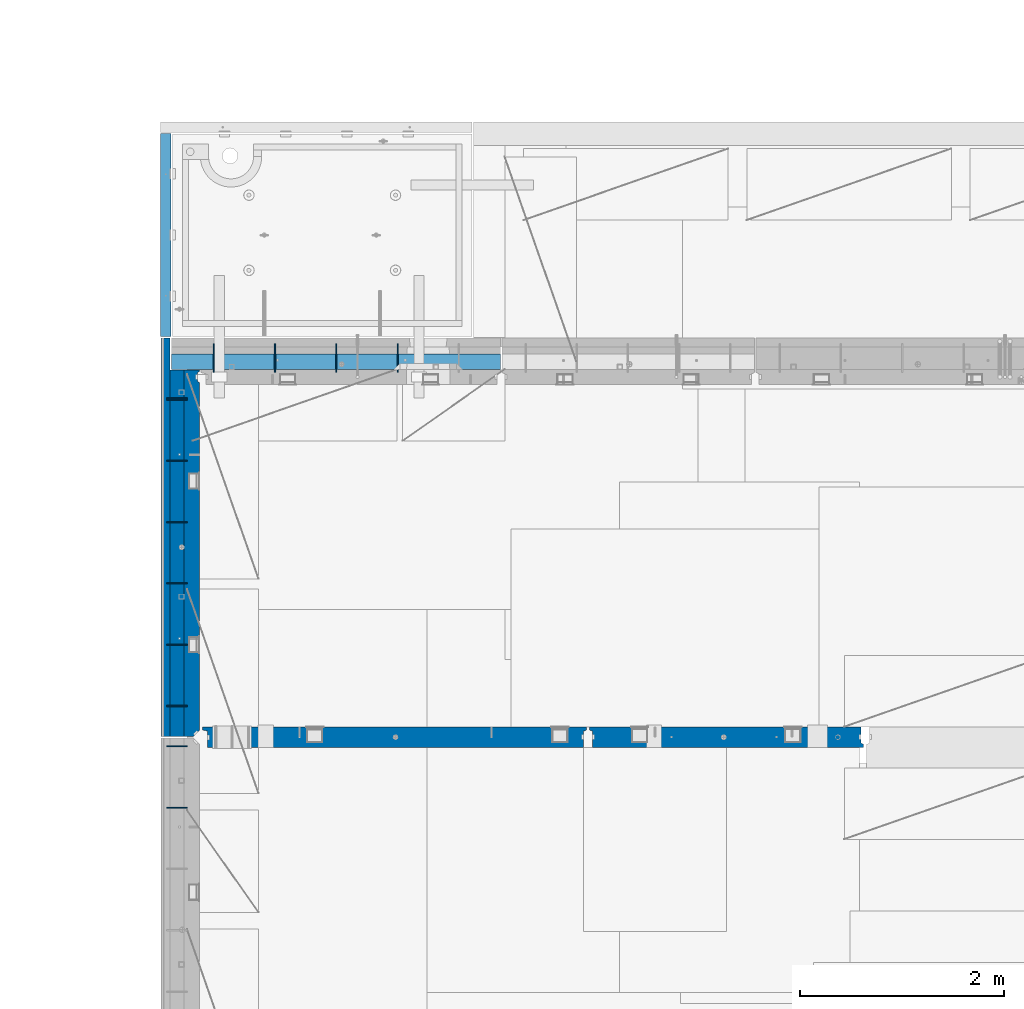
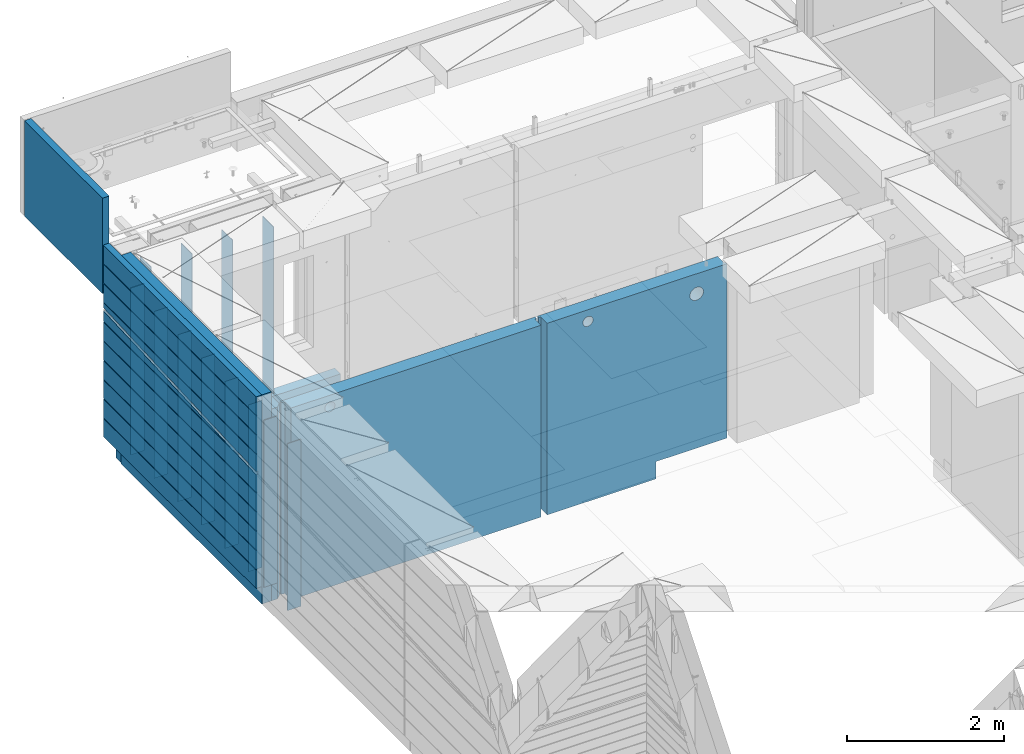
# One storey, part 214 of 325: 20 walls, 6 elements without a shape of their own.
"""IFC2X3 building model written with IfcOpenShell, lengths in millimetres."""

from ifc_helpers import new_model, si_unit, frame, origin_with_axes, place, context, subcontext, project, spatial, faceted_brep, material, type_object, element, aggregate, save


model = new_model("IFC2X3")

# Units and contexts
model_context = context("Model", 3, precision=1e-05, world=origin_with_axes())
body_context = subcontext(model_context, "Body", "Model", "MODEL_VIEW")
ifc_project = project(units=[si_unit("LENGTHUNIT", "METRE", prefix="MILLI"), si_unit("AREAUNIT", "SQUARE_METRE"), si_unit("VOLUMEUNIT", "CUBIC_METRE"), si_unit("MASSUNIT", "GRAM", prefix="KILO"), si_unit("TIMEUNIT", "SECOND"), si_unit("PLANEANGLEUNIT", "RADIAN"), si_unit("SOLIDANGLEUNIT", "STERADIAN"), si_unit("THERMODYNAMICTEMPERATUREUNIT", "DEGREE_CELSIUS"), si_unit("LUMINOUSINTENSITYUNIT", "LUMEN")], contexts=[model_context])

# Site, building, storey
site_placement = place(None, origin_with_axes())
site = spatial("IfcSite", under=ifc_project, at=site_placement, CompositionType="ELEMENT")
building_placement = place(site_placement, origin_with_axes())
building = spatial("IfcBuilding", under=site, at=building_placement, CompositionType="ELEMENT")
storey_placement = place(building_placement, origin_with_axes())
storey = spatial("IfcBuildingStorey", under=building, at=storey_placement, Name="1", CompositionType="ELEMENT", Elevation=0.0)

# Assembly, walls
assembly_1_placement = place(storey_placement, origin_with_axes())
assembly_1 = element("IfcElementAssembly", 1, at=assembly_1_placement, inside=storey, AssemblyPlace="NOTDEFINED", PredefinedType="REINFORCEMENT_UNIT")
ifc_material_1 = material(Name="Undefined")
wall_type_1 = type_object("IfcWallType", PredefinedType="NOTDEFINED")
wall_1_placement = place(assembly_1_placement, frame((7880.0, 20294.95, 83115.0), z_axis=(0.0, 0.0, 1.0), x_axis=(-1.0, 3.00000001838171e-08, 0.0)))
wall_1 = element("IfcWall", 2, at=wall_1_placement, type_object=wall_type_1, material=ifc_material_1, Name="(PD)", context=body_context, shape_type="Brep", body=[
    faceted_brep([(0.0, 5.0, -1300.0), (0.0, 5.0, 1300.0), (200.0, 5.0, 1300.0), (200.0, 5.0, -1300.0), (0.0, -5.0, 1300.0), (200.0, -5.0, 1300.0), (0.0, -5.0, -1300.0), (200.0, -5.0, -1300.0)], [[[0, 1, 2, 3]], [[1, 4, 5, 2]], [[4, 6, 7, 5]], [[6, 0, 3, 7]], [[5, 7, 3, 2]], [[6, 4, 1, 0]]]),
])
wall_2_placement = place(assembly_1_placement, frame((7880.0, 20284.95, 83115.0), z_axis=(0.0, 0.0, 1.0), x_axis=(-1.0, 3.00000001838171e-08, 0.0)))
wall_2 = element("IfcWall", 3, at=wall_2_placement, type_object=wall_type_1, material=ifc_material_1, Name="(PD)", context=body_context, shape_type="Brep", body=[
    faceted_brep([(0.0, 5.0, -1300.0), (0.0, 5.0, 1300.0), (200.0, 5.0, 1300.0), (200.0, 5.0, -1300.0), (0.0, -5.0, 1300.0), (200.0, -5.0, 1300.0), (0.0, -5.0, -1300.0), (200.0, -5.0, -1300.0)], [[[0, 1, 2, 3]], [[1, 4, 5, 2]], [[4, 6, 7, 5]], [[6, 0, 3, 7]], [[5, 7, 3, 2]], [[6, 4, 1, 0]]]),
])
wall_3_placement = place(assembly_1_placement, frame((7880.0, 19684.95, 83115.0), z_axis=(0.0, 0.0, 1.0), x_axis=(-1.0, 3.00000001838171e-08, 0.0)))
wall_3 = element("IfcWall", 4, at=wall_3_placement, type_object=wall_type_1, material=ifc_material_1, Name="(PD)", context=body_context, shape_type="Brep", body=[
    faceted_brep([(0.0, 5.0, -1300.0), (0.0, 5.0, 1300.0), (200.0, 5.0, 1300.0), (200.0, 5.0, -1300.0), (0.0, -5.0, 1300.0), (200.0, -5.0, 1300.0), (0.0, -5.0, -1300.0), (200.0, -5.0, -1300.0)], [[[0, 1, 2, 3]], [[1, 4, 5, 2]], [[4, 6, 7, 5]], [[6, 0, 3, 7]], [[5, 7, 3, 2]], [[6, 4, 1, 0]]]),
])
wall_4_placement = place(assembly_1_placement, frame((7880.0, 19084.95, 83115.0), z_axis=(0.0, 0.0, 1.0), x_axis=(-1.0, 3.00000001838171e-08, 0.0)))
wall_4 = element("IfcWall", 5, at=wall_4_placement, type_object=wall_type_1, material=ifc_material_1, Name="(PD)", context=body_context, shape_type="Brep", body=[
    faceted_brep([(0.0, 5.0, -1300.0), (0.0, 5.0, 1300.0), (200.0, 5.0, 1300.0), (200.0, 5.0, -1300.0), (0.0, -5.0, 1300.0), (200.0, -5.0, 1300.0), (0.0, -5.0, -1300.0), (200.0, -5.0, -1300.0)], [[[0, 1, 2, 3]], [[1, 4, 5, 2]], [[4, 6, 7, 5]], [[6, 0, 3, 7]], [[5, 7, 3, 2]], [[6, 4, 1, 0]]]),
])
wall_5_placement = place(assembly_1_placement, frame((7880.0, 18484.95, 83115.0), z_axis=(0.0, 0.0, 1.0), x_axis=(-1.0, 3.00000001838171e-08, 0.0)))
wall_5 = element("IfcWall", 6, at=wall_5_placement, type_object=wall_type_1, material=ifc_material_1, Name="(PD)", context=body_context, shape_type="Brep", body=[
    faceted_brep([(0.0, 5.0, -1300.0), (0.0, 5.0, 1300.0), (200.0, 5.0, 1300.0), (200.0, 5.0, -1300.0), (0.0, -5.0, 1300.0), (200.0, -5.0, 1300.0), (0.0, -5.0, -1300.0), (200.0, -5.0, -1300.0)], [[[0, 1, 2, 3]], [[1, 4, 5, 2]], [[4, 6, 7, 5]], [[6, 0, 3, 7]], [[5, 7, 3, 2]], [[6, 4, 1, 0]]]),
])
wall_6_placement = place(assembly_1_placement, frame((7880.0, 17884.95, 83115.0), z_axis=(0.0, 0.0, 1.0), x_axis=(-1.0, 3.00000001838171e-08, 0.0)))
wall_6 = element("IfcWall", 7, at=wall_6_placement, type_object=wall_type_1, material=ifc_material_1, Name="(PD)", context=body_context, shape_type="Brep", body=[
    faceted_brep([(0.0, 5.0, -1300.0), (0.0, 5.0, 1300.0), (200.0, 5.0, 1300.0), (200.0, 5.0, -1300.0), (0.0, -5.0, 1300.0), (200.0, -5.0, 1300.0), (0.0, -5.0, -1300.0), (200.0, -5.0, -1300.0)], [[[0, 1, 2, 3]], [[1, 4, 5, 2]], [[4, 6, 7, 5]], [[6, 0, 3, 7]], [[5, 7, 3, 2]], [[6, 4, 1, 0]]]),
])

assembly_2_placement = place(storey_placement, origin_with_axes())
assembly_2 = element("IfcElementAssembly", 8, at=assembly_2_placement, inside=storey, AssemblyPlace="NOTDEFINED", PredefinedType="REINFORCEMENT_UNIT")
wall_7_placement = place(assembly_2_placement, frame((7880.0, 16890.0, 83115.0), z_axis=(0.0, 0.0, 1.0), x_axis=(-1.0, 3.00000001838171e-08, 0.0)))
wall_7 = element("IfcWall", 9, at=wall_7_placement, type_object=wall_type_1, material=ifc_material_1, Name="(PD)", context=body_context, shape_type="Brep", body=[
    faceted_brep([(0.0, 5.0, -1300.0), (0.0, 5.0, 1300.0), (200.0, 5.0, 1300.0), (200.0, 5.0, -1300.0), (0.0, -5.0, 1300.0), (200.0, -5.0, 1300.0), (0.0, -5.0, -1300.0), (200.0, -5.0, -1300.0)], [[[0, 1, 2, 3]], [[1, 4, 5, 2]], [[4, 6, 7, 5]], [[6, 0, 3, 7]], [[5, 7, 3, 2]], [[6, 4, 1, 0]]]),
])
wall_8_placement = place(assembly_2_placement, frame((7880.0, 16290.0, 83115.0), z_axis=(0.0, 0.0, 1.0), x_axis=(-1.0, 3.00000001838171e-08, 0.0)))
wall_8 = element("IfcWall", 10, at=wall_8_placement, type_object=wall_type_1, material=ifc_material_1, Name="(PD)", context=body_context, shape_type="Brep", body=[
    faceted_brep([(0.0, 5.0, -1300.0), (0.0, 5.0, 1300.0), (200.0, 5.0, 1300.0), (200.0, 5.0, -1300.0), (0.0, -5.0, 1300.0), (200.0, -5.0, 1300.0), (0.0, -5.0, -1300.0), (200.0, -5.0, -1300.0)], [[[0, 1, 2, 3]], [[1, 4, 5, 2]], [[4, 6, 7, 5]], [[6, 0, 3, 7]], [[5, 7, 3, 2]], [[6, 4, 1, 0]]]),
])
aggregate(assembly_2, [wall_7, wall_8])

# Wall
wall_9_placement = place(assembly_1_placement, frame((7880.0, 17284.95, 83115.0), z_axis=(0.0, 0.0, 1.0), x_axis=(-1.0, 3.00000001838171e-08, 0.0)))
wall_9 = element("IfcWall", 11, at=wall_9_placement, type_object=wall_type_1, material=ifc_material_1, Name="(PD)", context=body_context, shape_type="Brep", body=[
    faceted_brep([(0.0, 5.0, -1300.0), (0.0, 5.0, 1300.0), (200.0, 5.0, 1300.0), (200.0, 5.0, -1300.0), (0.0, -5.0, 1300.0), (200.0, -5.0, 1300.0), (0.0, -5.0, -1300.0), (200.0, -5.0, -1300.0)], [[[0, 1, 2, 3]], [[1, 4, 5, 2]], [[4, 6, 7, 5]], [[6, 0, 3, 7]], [[5, 7, 3, 2]], [[6, 4, 1, 0]]]),
])

# Assembly, walls
assembly_3_placement = place(storey_placement, origin_with_axes())
assembly_3 = element("IfcElementAssembly", 12, at=assembly_3_placement, inside=storey, AssemblyPlace="NOTDEFINED", PredefinedType="REINFORCEMENT_UNIT")
wall_10_placement = place(assembly_3_placement, frame((8140.00024414063, 20549.9951872276, 83115.0), z_axis=(0.0, 0.0, 1.0), x_axis=(0.0, 1.0, 0.0)))
wall_10 = element("IfcWall", 13, at=wall_10_placement, type_object=wall_type_1, material=ifc_material_1, Name="(PD)", context=body_context, shape_type="Brep", body=[
    faceted_brep([(0.0, 5.0, -1300.0), (0.0, 5.0, 1300.0), (280.0, 5.0, 1300.0), (280.0, 5.0, -1300.0), (0.0, -5.0, 1300.0), (280.0, -5.0, 1300.0), (0.0, -5.0, -1300.0), (280.0, -5.0, -1300.0)], [[[0, 1, 2, 3]], [[1, 4, 5, 2]], [[4, 6, 7, 5]], [[6, 0, 3, 7]], [[5, 7, 3, 2]], [[6, 4, 1, 0]]]),
])
wall_11_placement = place(assembly_3_placement, frame((8740.00024414063, 20549.9951872276, 83115.0), z_axis=(0.0, 0.0, 1.0), x_axis=(0.0, 1.0, 0.0)))
wall_11 = element("IfcWall", 14, at=wall_11_placement, type_object=wall_type_1, material=ifc_material_1, Name="(PD)", context=body_context, shape_type="Brep", body=[
    faceted_brep([(0.0, 5.0, -1300.0), (0.0, 5.0, 1300.0), (280.0, 5.0, 1300.0), (280.0, 5.0, -1300.0), (0.0, -5.0, 1300.0), (280.0, -5.0, 1300.0), (0.0, -5.0, -1300.0), (280.0, -5.0, -1300.0)], [[[0, 1, 2, 3]], [[1, 4, 5, 2]], [[4, 6, 7, 5]], [[6, 0, 3, 7]], [[5, 7, 3, 2]], [[6, 4, 1, 0]]]),
])
wall_12_placement = place(assembly_3_placement, frame((9340.00024414063, 20549.9951872276, 83115.0), z_axis=(0.0, 0.0, 1.0), x_axis=(0.0, 1.0, 0.0)))
wall_12 = element("IfcWall", 15, at=wall_12_placement, type_object=wall_type_1, material=ifc_material_1, Name="(PD)", context=body_context, shape_type="Brep", body=[
    faceted_brep([(0.0, 5.0, -1300.0), (0.0, 5.0, 1300.0), (280.0, 5.0, 1300.0), (280.0, 5.0, -1300.0), (0.0, -5.0, 1300.0), (280.0, -5.0, 1300.0), (0.0, -5.0, -1300.0), (280.0, -5.0, -1300.0)], [[[0, 1, 2, 3]], [[1, 4, 5, 2]], [[4, 6, 7, 5]], [[6, 0, 3, 7]], [[5, 7, 3, 2]], [[6, 4, 1, 0]]]),
])
wall_13_placement = place(assembly_3_placement, frame((9940.00024414063, 20549.9951872276, 83115.0), z_axis=(0.0, 0.0, 1.0), x_axis=(0.0, 1.0, 0.0)))
wall_13 = element("IfcWall", 16, at=wall_13_placement, type_object=wall_type_1, material=ifc_material_1, Name="(PD)", context=body_context, shape_type="Brep", body=[
    faceted_brep([(0.0, 5.0, -1300.0), (0.0, 5.0, 1300.0), (280.0, 5.0, 1300.0), (280.0, 5.0, -1300.0), (0.0, -5.0, 1300.0), (280.0, -5.0, 1300.0), (0.0, -5.0, -1300.0), (280.0, -5.0, -1300.0)], [[[0, 1, 2, 3]], [[1, 4, 5, 2]], [[4, 6, 7, 5]], [[6, 0, 3, 7]], [[5, 7, 3, 2]], [[6, 4, 1, 0]]]),
])

# Wall
ifc_material_2 = material(Name="CONCRETE/C30/37")
wall_type_2 = type_object("IfcWallType", PredefinedType="NOTDEFINED")
wall_14_placement = place(assembly_1_placement, frame((7667.5, 16980.0, 83247.5), z_axis=(0.0, 0.0, 1.0), x_axis=(0.0, 1.0, 0.0)))
wall_14 = element("IfcWall", 17, at=wall_14_placement, type_object=wall_type_2, material=ifc_material_2, context=body_context, shape_type="Brep", body=[
    faceted_brep([(3905.0, 42.5, 467.601636793828), (617.757343419788, 42.5, 306.999999889245), (576.820751742882, 32.4999991121686, 305.000000400425), (372.137732831765, 32.499999250168, 294.999999999229), (331.201129576864, 42.5, 292.999999944761), (4.95000040170271, 42.5, 277.060666498321), (4.9500537408785, 12.4999999999927, 277.060666498321), (3904.99999990879, 12.4999999999927, 467.601636793828), (3905.0, 12.4999999999927, 517.601636486768), (4.95010360221204, 12.4999999999927, 327.060668622667), (4.95000040170271, 42.5, 327.060668622667), (3905.0, 42.5, 517.601636486768), (4.95000040170635, 32.499999250168, 594.999999999229), (4.95000040170635, 32.4999991121686, 605.000000400425), (3894.99999897938, 32.4999991121686, 605.000000400425), (3894.9999992586, 32.499999250168, 594.999999999229), (4.95000040170271, 32.499999250168, 894.999999999229), (4.95000040170271, 32.4999991121686, 905.000000400425), (3894.99999897938, 32.4999991121686, 905.000000400425), (3894.9999992586, 32.499999250168, 894.999999999229), (4.95000040170271, 32.499999250168, 1194.99999999923), (4.95000040170271, 32.4999991121686, 1205.00000040043), (3894.99999897938, 32.4999991121686, 1205.00000040043), (3894.9999992586, 32.499999250168, 1194.99999999923), (3905.0, 42.5, 892.999999944761), (3905.0, -42.5, 893.000001142951), (3904.99999378648, -42.5, 607.000001087436), (3905.0, 42.5, 606.999999889245), (3905.0, 42.5, 1192.99999994476), (3905.0, -42.5, 1193.00000114295), (3904.99999378648, -42.5, 907.000001087436), (3905.0, 42.5, 906.999999889245), (4.95000040170271, 42.5, 1492.5), (4.95000040170271, -42.5, 1492.5), (3905.0, -42.5, 1492.5), (3905.0, 42.5, 1492.5), (3905.0, -42.5, -1492.5), (3905.0, 42.5, -1492.5), (3905.0, 42.5, -1207.00000005524), (3905.0, -42.5, -1206.99999885705), (4.95000040170271, -42.5, -1492.5), (4.95000040170271, 42.5, -1492.5), (4.95000040170271, 42.5, -1207.00000005524), (4.95000040170271, 32.499999250168, -1205.00000000077), (3894.9999992586, 32.499999250168, -1205.00000000077), (3894.99999396347, -42.5, -1204.99999894381), (3894.99999897938, 32.4999991121686, -1194.99999959957), (3894.99999368425, -42.5, -1194.9999985426), (4.95000040170271, 32.4999991121686, -1194.99999959957), (3905.0, 42.5, -907.000000055239), (3905.0, -42.5, -906.999998857049), (3904.99999378648, -42.5, -1192.99999891256), (3905.0, 42.5, -1193.00000011075), (4.95000040170271, 32.499999250168, -905.000000000771), (4.95000040170271, 32.4999991121686, -894.999999599575), (3894.99999897938, 32.4999991121686, -894.999999599575), (3894.9999992586, 32.499999250168, -905.000000000771), (3905.0, 42.5, -607.000000055239), (3905.0, -42.5, -606.999998857049), (3904.99999378648, -42.5, -892.999998912564), (3905.0, 42.5, -893.000000110755), (4.95000040170271, 32.499999250168, -605.000000000771), (4.95000040170271, 32.4999991121686, -594.999999599575), (3894.99999897938, 32.4999991121686, -594.999999599575), (3894.9999992586, 32.499999250168, -605.000000000771), (3905.0, 42.5, -307.000000055239), (3905.0, -42.5, -306.999998857049), (3904.99999378648, -42.5, -592.999998912564), (3905.0, 42.5, -593.000000110755), (4.95000040170271, 32.499999250168, -305.000000000771), (4.95000040170271, 32.4999991121686, -294.999999599575), (3894.99999897938, 32.4999991121686, -294.999999599575), (3894.9999992586, 32.499999250168, -305.000000000771), (3905.0, 42.5, -7.00000005523907), (3905.0, -42.5, -6.99999885704892), (3904.99999378648, -42.5, -292.999998912564), (3905.0, 42.5, -293.000000110755), (3904.99999378648, -42.5, 307.000001087436), (3894.99999368425, -42.5, 305.000001457403), (3894.99999897938, 32.4999991121686, 305.000000400425), (3905.0, 42.5, 306.999999889245), (3894.99999396347, -42.5, 295.000001056193), (3894.9999992586, 32.499999250168, 294.999999999229), (3905.0, -42.5, 293.000001142951), (3905.0, 42.5, 292.999999944761), (3904.99999378648, -42.5, 7.00000108743552), (3905.0, 42.5, 6.99999988924537), (4.95000040169907, 32.499999250168, -5.00000000077125), (4.95000040169907, 32.4999991121686, 5.00000040042505), (3894.99999897938, 32.4999991121686, 5.00000040042505), (3894.9999992586, 32.499999250168, -5.00000000077125), (4.95000040170271, 42.5, 6.99999988924537), (3894.99999368425, -42.5000000000009, 5.00000145740341), (3894.99999396347, -42.5000000000009, -4.99999894380744), (4.95000040170271, 42.5, -7.00000005523907), (4.95000040170271, 42.5, -293.000000110755), (3894.99999368425, -42.5, -294.999998542597), (3894.99999396347, -42.5, -304.999998943807), (4.95000040170271, 42.5, -307.000000055239), (4.95000040170271, 42.5, -593.000000110755), (3894.99999368425, -42.5, -594.999998542597), (3894.99999396347, -42.5, -604.999998943807), (4.95000040170271, 42.5, -607.000000055239), (4.95000040170271, 42.5, -893.000000110755), (3894.99999368425, -42.5, -894.999998542597), (3894.99999396347, -42.5, -904.999998943807), (4.95000040170271, 42.5, -907.000000055239), (4.95000040170271, 42.5, -1193.00000011075), (3905.0, -42.5, 593.000001142951), (3894.99999396347, -42.5, 595.000001056193), (3894.99999368425, -42.5, 605.000001457403), (3894.99999396347, -42.5, 895.000001056193), (3894.99999368425, -42.5, 905.000001457403), (3894.99999396347, -42.5, 1195.00000105619), (3894.99999368425, -42.5, 1205.0000014574), (3904.99999378648, -42.5, 1207.00000108744), (3905.0, 42.5, 1206.99999988925), (4.95000040170271, 42.5, 1206.99999988925), (4.95000040170271, 42.5, 1192.99999994476), (4.95000040170271, 42.5, 906.999999889245), (4.95000040170271, 42.5, 892.999999944761), (4.95000040170271, 42.5, 606.999999889245), (3905.0, 42.5, 592.999999944761), (4.95000040170271, 42.5, 592.999999944761)], [[[0, 1, 2, 3, 4, 5, 6, 7]], [[8, 9, 10, 11]], [[7, 6, 9, 8]], [[12, 13, 14, 15]], [[16, 17, 18, 19]], [[20, 21, 22, 23]], [[24, 25, 26, 27]], [[28, 29, 30, 31]], [[32, 33, 34, 35]], [[36, 37, 38, 39]], [[40, 41, 37, 36]], [[37, 41, 42, 38]], [[42, 43, 44, 38]], [[39, 38, 44, 45]], [[45, 44, 46, 47]], [[43, 48, 46, 44]], [[49, 50, 51, 52]], [[53, 54, 55, 56]], [[57, 58, 59, 60]], [[61, 62, 63, 64]], [[65, 66, 67, 68]], [[69, 70, 71, 72]], [[73, 74, 75, 76]], [[77, 78, 79, 80]], [[81, 82, 79, 78]], [[83, 84, 82, 81]], [[84, 83, 85, 86]], [[87, 88, 89, 90]], [[88, 91, 86, 89]], [[85, 92, 89, 86]], [[93, 90, 89, 92]], [[74, 73, 90, 93]], [[94, 87, 90, 73]], [[76, 95, 94, 73]], [[70, 95, 76, 71]], [[75, 96, 71, 76]], [[97, 72, 71, 96]], [[66, 65, 72, 97]], [[98, 69, 72, 65]], [[68, 99, 98, 65]], [[62, 99, 68, 63]], [[67, 100, 63, 68]], [[101, 64, 63, 100]], [[58, 57, 64, 101]], [[102, 61, 64, 57]], [[60, 103, 102, 57]], [[54, 103, 60, 55]], [[59, 104, 55, 60]], [[105, 56, 55, 104]], [[50, 49, 56, 105]], [[106, 53, 56, 49]], [[52, 107, 106, 49]], [[48, 107, 52, 46]], [[51, 47, 46, 52]], [[50, 105, 104, 59, 58, 101, 100, 67, 66, 97, 96, 75, 74, 93, 92, 85, 83, 81, 78, 77, 108, 109, 110, 26, 25, 111, 112, 30, 29, 113, 114, 115, 34, 33, 40, 36, 39, 45, 47, 51]], [[35, 34, 115, 116]], [[32, 35, 116, 117]], [[21, 117, 116, 22]], [[115, 114, 22, 116]], [[113, 23, 22, 114]], [[29, 28, 23, 113]], [[118, 20, 23, 28]], [[31, 119, 118, 28]], [[17, 119, 31, 18]], [[30, 112, 18, 31]], [[111, 19, 18, 112]], [[25, 24, 19, 111]], [[120, 16, 19, 24]], [[27, 121, 120, 24]], [[13, 121, 27, 14]], [[26, 110, 14, 27]], [[109, 15, 14, 110]], [[108, 122, 15, 109]], [[123, 12, 15, 122]], [[123, 122, 11, 10]], [[5, 91, 88, 87, 94, 95, 70, 69, 98, 99, 62, 61, 102, 103, 54, 53, 106, 107, 48, 43, 42, 41, 40, 33, 32, 117, 21, 20, 118, 119, 17, 16, 120, 121, 13, 12, 123, 10, 9, 6]], [[84, 86, 91, 5, 4]], [[82, 84, 4, 3]], [[79, 82, 3, 2]], [[80, 79, 2, 1]], [[80, 1, 0]], [[122, 108, 77, 80, 0, 7, 8, 11]]]),
])

ifc_material_3 = material(Name="CONCRETE/C25/30")
wall_type_3 = type_object("IfcWallType", PredefinedType="NOTDEFINED")
wall_15_placement = place(assembly_1_placement, frame((7925.0, 16980.0, 82977.5), z_axis=(0.0, 0.0, 1.0), x_axis=(0.0, 1.0, 0.0)))
wall_15 = element("IfcWall", 18, at=wall_15_placement, type_object=wall_type_3, material=ifc_material_3, context=body_context, shape_type="Brep", body=[
    faceted_brep([(64.9500004017027, -75.0, 1492.5), (4.95000040170271, -15.0, 1492.5), (4.95000040170271, -15.0, -1492.5), (64.9500004017027, -75.0, -1492.5), (4.95000040170271, 75.0, -1492.5), (4.95000040170271, 75.0, 1492.5), (3595.0, 75.0, 1492.5), (3595.0, 75.0, -1492.5), (3595.0, -75.0, 1492.5), (3595.0, -75.0, -1492.5), (3579.99518722756, -75.0, 1492.5), (3579.99518722756, -75.0, -1492.5), (3566.99518722756, -55.0, 1492.5), (3566.99518722756, -55.0, -1492.5), (3482.99518722756, -55.0, 1492.5), (3482.99518722756, -55.0, -1492.5), (3469.99518722757, -75.0, 1492.5), (3469.99518722757, -75.0, -1492.5)], [[[0, 1, 2, 3]], [[4, 5, 6, 7]], [[8, 9, 7, 6]], [[9, 8, 10, 11]], [[10, 12, 13, 11]], [[14, 15, 13, 12]], [[16, 17, 15, 14]], [[17, 16, 0, 3]], [[4, 7, 9, 11, 13, 15, 17, 3, 2]], [[5, 4, 2, 1]], [[16, 14, 12, 10, 8, 6, 5, 1, 0]]]),
])

ifc_material_4 = material(Name="SPU")
wall_type_4 = type_object("IfcWallType", PredefinedType="NOTDEFINED")
wall_16_placement = place(assembly_3_placement, frame((10945.0, 20654.9951872276, 81620.0), z_axis=(0.0, 0.0, 1.0), x_axis=(-1.0, 3.00000001838171e-08, 0.0)))
wall_16 = element("IfcWall", 19, at=wall_16_placement, type_object=wall_type_4, material=ifc_material_4, context=body_context, shape_type="Brep", body=[
    faceted_brep([(0.0, 75.0, -135.0), (0.0, 75.0, 135.0), (3220.0, 75.0, 135.0), (3220.0, 75.0, -135.0), (0.0, -75.0, 135.0), (3220.0, -75.0, 135.0), (0.0, -75.0, -135.0), (3220.0, -75.0, -135.0)], [[[0, 1, 2, 3]], [[1, 4, 5, 2]], [[4, 6, 7, 5]], [[6, 0, 3, 7]], [[5, 7, 3, 2]], [[6, 4, 1, 0]]]),
])

aggregate(assembly_3, [wall_16, wall_10, wall_11, wall_12, wall_13])

# Assembly, wall
assembly_4_placement = place(storey_placement, origin_with_axes())
assembly_4 = element("IfcElementAssembly", 20, at=assembly_4_placement, inside=storey, AssemblyPlace="NOTDEFINED", PredefinedType="REINFORCEMENT_UNIT")
wall_type_5 = type_object("IfcWallType", PredefinedType="NOTDEFINED")
wall_17_placement = place(assembly_4_placement, frame((7669.99985681325, 20899.9965573523, 84717.5), z_axis=(0.0, 0.0, 1.0), x_axis=(0.0, 1.0, 0.0)))
wall_17 = element("IfcWall", 21, at=wall_17_placement, type_object=wall_type_5, material=ifc_material_2, context=body_context, shape_type="Brep", body=[
    faceted_brep([(0.0, 50.0, -742.5), (0.0, 50.0, 742.5), (1990.00366210156, 50.0, 742.5), (1990.00366210156, 50.0, -742.5), (0.0, -50.0, 742.5), (1990.00366210156, -50.0, 742.5), (0.0, -50.0, -742.5), (1990.00366210156, -50.0, -742.5)], [[[0, 1, 2, 3]], [[1, 4, 5, 2]], [[4, 6, 7, 5]], [[6, 0, 3, 7]], [[5, 7, 3, 2]], [[6, 4, 1, 0]]]),
])
aggregate(assembly_4, [wall_17])

# Wall
wall_type_6 = type_object("IfcWallType", PredefinedType="NOTDEFINED")
wall_18_placement = place(assembly_1_placement, frame((7780.0, 16980.0, 83112.5), z_axis=(0.0, 0.0, 1.0), x_axis=(0.0, 1.0, 0.0)))
wall_18 = element("IfcWall", 22, at=wall_18_placement, type_object=wall_type_6, material=ifc_material_4, context=body_context, shape_type="Brep", body=[
    faceted_brep([(4.95000040170271, 70.0, -1627.5), (4.95000040170271, 70.0, 1627.5), (3595.0, 70.0, 1627.5), (3595.0, 70.0, -1627.5), (4.95000040170271, -70.0, 1627.5), (3595.0, -70.0, 1627.5), (4.95000040170271, -70.0, -1627.5), (3595.0, -70.0, -1627.5)], [[[0, 1, 2, 3]], [[1, 4, 5, 2]], [[4, 6, 7, 5]], [[6, 0, 3, 7]], [[5, 7, 3, 2]], [[6, 4, 1, 0]]]),
])

aggregate(assembly_1, [wall_1, wall_2, wall_3, wall_4, wall_5, wall_6, wall_9, wall_14, wall_18, wall_15])

# Assembly, wall
assembly_5_placement = place(storey_placement, origin_with_axes())
assembly_5 = element("IfcElementAssembly", 23, at=assembly_5_placement, inside=storey, AssemblyPlace="NOTDEFINED", PredefinedType="REINFORCEMENT_UNIT")
wall_type_7 = type_object("IfcWallType", PredefinedType="NOTDEFINED")
wall_19_placement = place(assembly_5_placement, frame((11795.0, 16980.0, 82977.5), z_axis=(0.0, 0.0, 1.0), x_axis=(1.0, 0.0, 0.0)))
wall_19 = element("IfcWall", 24, at=wall_19_placement, type_object=wall_type_7, material=ifc_material_3, context=body_context, shape_type="Brep", body=[
    faceted_brep([(727.216303462521, 100.0, 1331.91142838269), (727.216303462521, -100.0, 1331.91142838269), (719.723771774674, -100.0, 1350.0), (719.723771774674, 100.0, 1350.0), (707.804875079832, -100.0, 1365.53300858899), (707.804875079832, 100.0, 1365.53300858899), (692.271866490841, -100.0, 1377.45190528383), (692.271866490841, 100.0, 1377.45190528383), (674.18329487353, -100.0, 1384.94443697168), (674.18329487353, 100.0, 1384.94443697168), (654.771866490841, -100.0, 1387.5), (654.771866490841, 100.0, 1387.5), (635.360438108151, -100.0, 1384.94443697168), (635.360438108151, 100.0, 1384.94443697168), (617.271866490841, -100.0, 1377.45190528383), (617.271866490841, 100.0, 1377.45190528383), (601.73885790185, -100.0, 1365.53300858899), (601.73885790185, 100.0, 1365.53300858899), (589.819961207008, -100.0, 1350.0), (589.819961207008, 100.0, 1350.0), (582.32742951916, -100.0, 1331.91142838269), (582.32742951916, 100.0, 1331.91142838269), (579.771866490841, -100.0, 1312.5), (579.771866490841, 100.0, 1312.5), (582.32742951916, -100.0, 1293.08857161731), (582.32742951916, 100.0, 1293.08857161731), (589.819961207008, -100.0, 1275.0), (589.819961207008, 100.0, 1275.0), (601.73885790185, -100.0, 1259.46699141101), (601.73885790185, 100.0, 1259.46699141101), (617.271866490841, -100.0, 1247.54809471617), (617.271866490841, 100.0, 1247.54809471617), (635.360438108151, -100.0, 1240.05556302832), (635.360438108151, 100.0, 1240.05556302832), (654.771866490841, -100.0, 1237.5), (654.771866490841, 100.0, 1237.5), (674.18329487353, -100.0, 1240.05556302832), (674.18329487353, 100.0, 1240.05556302832), (692.271866490841, -100.0, 1247.54809471617), (692.271866490841, 100.0, 1247.54809471617), (707.804875079832, -100.0, 1259.46699141101), (707.804875079832, 100.0, 1259.46699141101), (719.723771774674, -100.0, 1275.0), (719.723771774674, 100.0, 1275.0), (727.216303462521, -100.0, 1293.08857161731), (727.216303462521, 100.0, 1293.08857161731), (729.771866490841, -100.0, 1312.5), (729.771866490841, 100.0, 1312.5), (25.0, 70.0, 1492.5), (25.0, 70.0, -1492.5), (55.0, 57.0, -1492.5), (55.0, 57.0, 1492.5), (25.0, 100.0, 1492.5), (25.0, 100.0, -1492.5), (1655.0033738431, 100.0, -1222.5), (1655.0033738431, -100.0, -1222.5), (1655.0033738431, -100.0, -1492.5), (1655.0033738431, 100.0, -1492.5), (55.0, -100.0, -1492.5), (55.0, -100.0, 1492.5), (2680.0, 100.0, 1492.5), (2705.0, -100.0, 1492.5), (2705.0, -67.8333333333321, 1492.5), (2680.0, -57.0, 1492.5), (2705.0, -100.0, -1222.5), (2704.99995587435, -67.8333333333321, -1222.5), (2680.0, -57.0, -1222.5), (2680.0, 100.0, -1222.5), (2342.15440686929, 100.0, 1232.5), (2326.2625446095, 100.0, 1253.21067811866), (2305.55186649084, 100.0, 1269.10254037844), (2281.43377100109, 100.0, 1279.0925826289), (2255.55186649084, 100.0, 1282.5), (2229.66996198059, 100.0, 1279.0925826289), (2205.55186649084, 100.0, 1269.10254037844), (2184.84118837219, 100.0, 1253.21067811866), (2168.9493261124, 100.0, 1232.5), (2158.95928386193, 100.0, 1208.38190451026), (2155.55186649084, 100.0, 1182.5), (2158.95928386193, 100.0, 1156.61809548974), (2168.9493261124, 100.0, 1132.5), (2184.84118837219, 100.0, 1111.78932188134), (2205.55186649084, 100.0, 1095.89745962156), (2229.66996198059, 100.0, 1085.9074173711), (2255.55186649084, 100.0, 1082.5), (2281.43377100109, 100.0, 1085.9074173711), (2305.55186649084, 100.0, 1095.89745962156), (2326.2625446095, 100.0, 1111.78932188134), (2342.15440686929, 100.0, 1132.5), (2352.14444911975, 100.0, 1156.61809548974), (2355.55186649084, 100.0, 1182.5), (2352.14444911975, 100.0, 1208.38190451026), (2342.15440686929, -100.037876245973, 1132.5), (2352.14444911975, -100.037876245973, 1156.61809548974), (2326.2625446095, -100.037876245973, 1111.78932188134), (2305.55186649084, -100.037876245973, 1095.89745962156), (2281.43377100109, -100.037876245973, 1085.9074173711), (2255.55186649084, -100.037876245973, 1082.5), (2229.66996198059, -100.037876245973, 1085.9074173711), (2205.55186649084, -100.037876245973, 1095.89745962156), (2184.84118837219, -100.037876245973, 1111.78932188134), (2168.9493261124, -100.037876245973, 1132.5), (2158.95928386193, -100.037876245973, 1156.61809548974), (2155.55186649084, -100.037876245973, 1182.5), (2158.95928386193, -100.037876245973, 1208.38190451026), (2168.9493261124, -100.037876245973, 1232.5), (2184.84118837219, -100.037876245973, 1253.21067811866), (2205.55186649084, -100.037876245973, 1269.10254037844), (2229.66996198059, -100.037876245973, 1279.0925826289), (2255.55186649084, -100.037876245973, 1282.5), (2281.43377100109, -100.037876245973, 1279.0925826289), (2305.55186649084, -100.037876245973, 1269.10254037844), (2326.2625446095, -100.037876245973, 1253.21067811866), (2342.15440686929, -100.037876245973, 1232.5), (2352.14444911975, -100.037876245973, 1208.38190451026), (2355.55186649084, -100.037876245973, 1182.5)], [[[0, 1, 2, 3]], [[3, 2, 4, 5]], [[5, 4, 6, 7]], [[7, 6, 8, 9]], [[9, 8, 10, 11]], [[11, 10, 12, 13]], [[13, 12, 14, 15]], [[15, 14, 16, 17]], [[17, 16, 18, 19]], [[19, 18, 20, 21]], [[21, 20, 22, 23]], [[23, 22, 24, 25]], [[25, 24, 26, 27]], [[27, 26, 28, 29]], [[29, 28, 30, 31]], [[31, 30, 32, 33]], [[33, 32, 34, 35]], [[35, 34, 36, 37]], [[37, 36, 38, 39]], [[39, 38, 40, 41]], [[41, 40, 42, 43]], [[43, 42, 44, 45]], [[45, 44, 46, 47]], [[47, 46, 1, 0]], [[48, 49, 50, 51]], [[52, 53, 49, 48]], [[54, 55, 56, 57]], [[58, 50, 49, 53, 57, 56]], [[51, 50, 58, 59]], [[60, 52, 48, 51, 59, 61, 62, 63]], [[62, 61, 64, 65]], [[63, 62, 65, 66]], [[60, 63, 66, 67]], [[65, 64, 55, 54, 67, 66]], [[57, 53, 52, 60, 67, 54], [3, 5, 7, 9, 11, 13, 15, 17, 19, 21, 23, 25, 27, 29, 31, 33, 35, 37, 39, 41, 43, 45, 47, 0], [68, 69, 70, 71, 72, 73, 74, 75, 76, 77, 78, 79, 80, 81, 82, 83, 84, 85, 86, 87, 88, 89, 90, 91]], [[88, 92, 93, 89]], [[87, 94, 92, 88]], [[86, 95, 94, 87]], [[85, 96, 95, 86]], [[84, 97, 96, 85]], [[83, 98, 97, 84]], [[82, 99, 98, 83]], [[81, 100, 99, 82]], [[80, 101, 100, 81]], [[79, 102, 101, 80]], [[78, 103, 102, 79]], [[77, 104, 103, 78]], [[76, 105, 104, 77]], [[75, 106, 105, 76]], [[74, 107, 106, 75]], [[73, 108, 107, 74]], [[72, 109, 108, 73]], [[71, 110, 109, 72]], [[70, 111, 110, 71]], [[69, 112, 111, 70]], [[68, 113, 112, 69]], [[91, 114, 113, 68]], [[90, 115, 114, 91]], [[89, 93, 115, 90]], [[61, 59, 58, 56, 55, 64], [42, 40, 38, 36, 34, 32, 30, 28, 26, 24, 22, 20, 18, 16, 14, 12, 10, 8, 6, 4, 2, 1, 46, 44], [92, 94, 95, 96, 97, 98, 99, 100, 101, 102, 103, 104, 105, 106, 107, 108, 109, 110, 111, 112, 113, 114, 115, 93]]]),
])
aggregate(assembly_5, [wall_19])

assembly_6_placement = place(storey_placement, origin_with_axes())
assembly_6 = element("IfcElementAssembly", 25, at=assembly_6_placement, inside=storey, AssemblyPlace="NOTDEFINED", PredefinedType="REINFORCEMENT_UNIT")
wall_20_placement = place(assembly_6_placement, frame((8000.0, 16980.0, 82977.5), z_axis=(0.0, 0.0, 1.0), x_axis=(1.0, 0.0, 0.0)))
wall_20 = element("IfcWall", 26, at=wall_20_placement, type_object=wall_type_7, material=ifc_material_3, context=body_context, shape_type="Brep", body=[
    faceted_brep([(722.446303462522, 100.0, 1329.91142838269), (722.446303462522, -100.0, 1329.91142838269), (714.953771774675, -100.0, 1348.0), (714.953771774675, 100.0, 1348.0), (703.034875079833, -100.0, 1363.53300858899), (703.034875079833, 100.0, 1363.53300858899), (687.501866490842, -100.0, 1375.45190528383), (687.501866490842, 100.0, 1375.45190528383), (669.413294873531, -100.0, 1382.94443697168), (669.413294873531, 100.0, 1382.94443697168), (650.001866490842, -100.0, 1385.5), (650.001866490842, 100.0, 1385.5), (630.590438108153, -100.0, 1382.94443697168), (630.590438108153, 100.0, 1382.94443697168), (612.501866490842, -100.0, 1375.45190528383), (612.501866490842, 100.0, 1375.45190528383), (596.968857901851, -100.0, 1363.53300858899), (596.968857901851, 100.0, 1363.53300858899), (585.049961207009, -100.0, 1348.0), (585.049961207009, 100.0, 1348.0), (577.557429519162, -100.0, 1329.91142838269), (577.557429519162, 100.0, 1329.91142838269), (575.001866490842, -100.0, 1310.5), (575.001866490842, 100.0, 1310.5), (577.557429519162, -100.0, 1291.08857161731), (577.557429519162, 100.0, 1291.08857161731), (585.049961207009, -100.0, 1273.0), (585.049961207009, 100.0, 1273.0), (596.968857901851, -100.0, 1257.46699141101), (596.968857901851, 100.0, 1257.46699141101), (612.501866490842, -100.0, 1245.54809471617), (612.501866490842, 100.0, 1245.54809471617), (630.590438108153, -100.0, 1238.05556302832), (630.590438108153, 100.0, 1238.05556302832), (650.001866490842, -100.0, 1235.5), (650.001866490842, 100.0, 1235.5), (669.413294873531, -100.0, 1238.05556302832), (669.413294873531, 100.0, 1238.05556302832), (687.501866490842, -100.0, 1245.54809471617), (687.501866490842, 100.0, 1245.54809471617), (703.034875079833, -100.0, 1257.46699141101), (703.034875079833, 100.0, 1257.46699141101), (714.953771774675, -100.0, 1273.0), (714.953771774675, 100.0, 1273.0), (722.446303462522, -100.0, 1291.08857161731), (722.446303462522, 100.0, 1291.08857161731), (725.001866490842, -100.0, 1310.5), (725.001866490842, 100.0, 1310.5), (3760.0, -100.0, 1492.5), (3760.0, 57.0, 1492.5), (3790.0, 70.0, 1492.5), (3790.0, 100.0, 1492.5), (30.0, 100.0, 1492.5), (30.0, 69.9000008034018, 1492.5), (80.0, 59.9000008034018, 1492.5), (80.0, -100.0, 1492.5), (3760.0, -100.0, -1492.5), (3760.0, 57.0, -1492.5), (3790.0, 70.0, -1492.5), (3790.0, 100.0, -1492.5), (30.0, 100.0, -1492.5), (30.0, 69.9000008034018, -1492.5), (80.0, 59.9000008034018, -1492.5), (80.0, -100.0, -1492.5)], [[[0, 1, 2, 3]], [[3, 2, 4, 5]], [[5, 4, 6, 7]], [[7, 6, 8, 9]], [[9, 8, 10, 11]], [[11, 10, 12, 13]], [[13, 12, 14, 15]], [[15, 14, 16, 17]], [[17, 16, 18, 19]], [[19, 18, 20, 21]], [[21, 20, 22, 23]], [[23, 22, 24, 25]], [[25, 24, 26, 27]], [[27, 26, 28, 29]], [[29, 28, 30, 31]], [[31, 30, 32, 33]], [[33, 32, 34, 35]], [[35, 34, 36, 37]], [[37, 36, 38, 39]], [[39, 38, 40, 41]], [[41, 40, 42, 43]], [[43, 42, 44, 45]], [[45, 44, 46, 47]], [[47, 46, 1, 0]], [[48, 49, 50, 51, 52, 53, 54, 55]], [[48, 56, 57, 49]], [[50, 49, 57, 58]], [[59, 51, 50, 58]], [[60, 52, 51, 59], [3, 5, 7, 9, 11, 13, 15, 17, 19, 21, 23, 25, 27, 29, 31, 33, 35, 37, 39, 41, 43, 45, 47, 0]], [[52, 60, 61, 53]], [[53, 61, 62, 54]], [[60, 59, 58, 57, 56, 63, 62, 61]], [[54, 62, 63, 55]], [[56, 48, 55, 63], [42, 40, 38, 36, 34, 32, 30, 28, 26, 24, 22, 20, 18, 16, 14, 12, 10, 8, 6, 4, 2, 1, 46, 44]]]),
])
aggregate(assembly_6, [wall_20])

save(model, "model.ifc")
